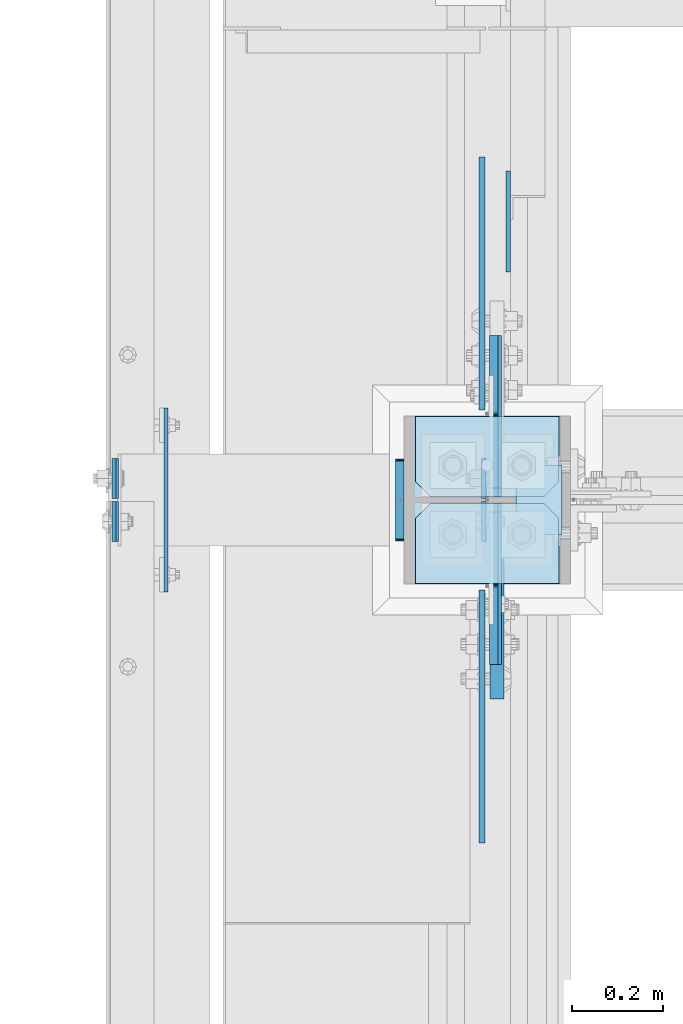
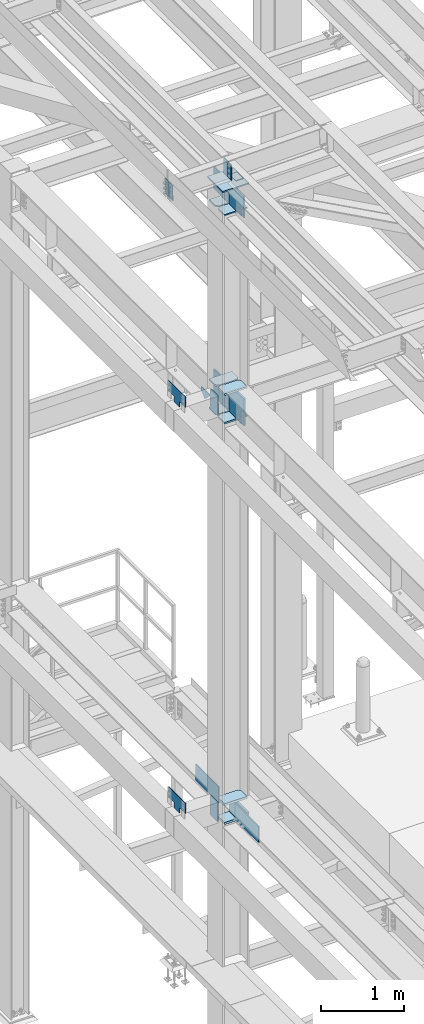
# One storey, part 3390 of 3843: 26 plates, 5 elements without a shape of their own.
"""IFC2X3 building model written with IfcOpenShell, lengths in millimetres."""

from ifc_helpers import new_model, si_unit, frame, origin_with_axes, place, context, subcontext, project, spatial, faceted_brep, material, type_object, element, aggregate, save


model = new_model("IFC2X3")

# Units and contexts
model_context = context("Model", 3, precision=1e-05, world=origin_with_axes())
body_context = subcontext(model_context, "Body", "Model", "MODEL_VIEW")
ifc_project = project(units=[si_unit("LENGTHUNIT", "METRE", prefix="MILLI"), si_unit("AREAUNIT", "SQUARE_METRE"), si_unit("VOLUMEUNIT", "CUBIC_METRE"), si_unit("MASSUNIT", "GRAM", prefix="KILO"), si_unit("TIMEUNIT", "SECOND"), si_unit("PLANEANGLEUNIT", "RADIAN"), si_unit("SOLIDANGLEUNIT", "STERADIAN"), si_unit("THERMODYNAMICTEMPERATUREUNIT", "DEGREE_CELSIUS"), si_unit("LUMINOUSINTENSITYUNIT", "LUMEN")], contexts=[model_context])

# Site, building, storey
site_placement = place(None, origin_with_axes())
site = spatial("IfcSite", under=ifc_project, at=site_placement, CompositionType="ELEMENT")
building_placement = place(site_placement, origin_with_axes())
building = spatial("IfcBuilding", under=site, at=building_placement, Name="Undefined", CompositionType="ELEMENT")
storey_placement = place(building_placement, origin_with_axes())
storey = spatial("IfcBuildingStorey", under=building, at=storey_placement, Name="Undefined", CompositionType="ELEMENT", Elevation=0.0)

# Assembly, plates
assembly_1_placement = place(storey_placement, origin_with_axes())
assembly_1 = element("IfcElementAssembly", 1, at=assembly_1_placement, inside=storey, Name="COLUMN", AssemblyPlace="NOTDEFINED", PredefinedType="RIGID_FRAME")
ifc_material = material(Name="STEEL/A572-50")
plate_type_1 = type_object("IfcPlateType", PredefinedType="NOTDEFINED")
plate_1_placement = place(assembly_1_placement, frame((36417.25, 83800.15625, 42005.249987793), z_axis=(1.0, 0.0, 0.0), x_axis=(0.0, 1.0, 0.0)))
plate_1 = element("IfcPlate", 2, at=plate_1_placement, type_object=plate_type_1, material=ifc_material, Name="PLATE", context=body_context, shape_type="Brep", body=[
    faceted_brep([(0.0, -12.6999999999971, 0.0), (0.0, -12.7000000020344, 317.500000001608), (0.0, 12.6999999977998, 317.500000001586), (0.0, 12.6999999999971, 0.0), (144.462501525879, -12.6999999999971, 317.5), (144.462501525879, 12.6999999999971, 317.5), (177.800003051758, -12.6999999999971, 284.162498474121), (177.800003051758, 12.6999999999971, 284.162498474121), (177.800003051758, -12.6999999999971, 33.3375015258789), (177.800003051758, 12.6999999999971, 33.3375015258789), (144.462501525879, -12.6999999999971, 0.0), (144.462501525879, 12.6999999999971, 0.0)], [[[0, 1, 2, 3]], [[1, 4, 5, 2]], [[4, 6, 7, 5]], [[6, 8, 9, 7]], [[8, 10, 11, 9]], [[10, 0, 3, 11]], [[5, 7, 9, 11, 3, 2]], [[10, 8, 6, 4, 1, 0]]]),
])
plate_2_placement = place(assembly_1_placement, frame((36417.25, 83800.15625, 42424.35), z_axis=(1.0, 0.0, 0.0), x_axis=(0.0, 1.0, 0.0)))
plate_2 = element("IfcPlate", 3, at=plate_2_placement, type_object=plate_type_1, material=ifc_material, Name="PLATE", context=body_context, shape_type="Brep", body=[
    faceted_brep([(0.0, -12.6999999999971, 0.0), (0.0, -12.7000000020344, 317.500000001608), (0.0, 12.6999999977998, 317.500000001586), (0.0, 12.6999999999971, 0.0), (144.462501525879, -12.6999999999971, 317.5), (144.462501525879, 12.6999999999971, 317.5), (177.800003051758, -12.6999999999971, 284.162498474121), (177.800003051758, 12.6999999999971, 284.162498474121), (177.800003051758, -12.6999999999971, 33.3375015258789), (177.800003051758, 12.6999999999971, 33.3375015258789), (144.462501525879, -12.6999999999971, 0.0), (144.462501525879, 12.6999999999971, 0.0)], [[[0, 1, 2, 3]], [[1, 4, 5, 2]], [[4, 6, 7, 5]], [[6, 8, 9, 7]], [[8, 10, 11, 9]], [[10, 0, 3, 11]], [[5, 7, 9, 11, 3, 2]], [[10, 8, 6, 4, 1, 0]]]),
])
plate_3_placement = place(assembly_1_placement, frame((36734.75, 84170.04375, 42005.249987793), z_axis=(-1.0, 0.0, 0.0), x_axis=(0.0, -1.0, 0.0)))
plate_3 = element("IfcPlate", 4, at=plate_3_placement, type_object=plate_type_1, material=ifc_material, Name="PLATE", context=body_context, shape_type="Brep", body=[
    faceted_brep([(0.0, -12.6999999999971, 0.0), (0.0, -12.7000000020344, 317.500000001608), (0.0, 12.6999999977998, 317.500000001586), (0.0, 12.6999999999971, 0.0), (144.462501525879, -12.6999999999971, 317.5), (144.462501525879, 12.6999999999971, 317.5), (177.800003051758, -12.6999999999971, 284.162498474121), (177.800003051758, 12.6999999999971, 284.162498474121), (177.800003051758, -12.6999999999971, 33.3375015258789), (177.800003051758, 12.6999999999971, 33.3375015258789), (144.462501525879, -12.6999999999971, 0.0), (144.462501525879, 12.6999999999971, 0.0)], [[[0, 1, 2, 3]], [[1, 4, 5, 2]], [[4, 6, 7, 5]], [[6, 8, 9, 7]], [[8, 10, 11, 9]], [[10, 0, 3, 11]], [[5, 7, 9, 11, 3, 2]], [[10, 8, 6, 4, 1, 0]]]),
])
plate_4_placement = place(assembly_1_placement, frame((36734.75, 84170.04375, 42424.35), z_axis=(-1.0, 0.0, 0.0), x_axis=(0.0, -1.0, 0.0)))
plate_4 = element("IfcPlate", 5, at=plate_4_placement, type_object=plate_type_1, material=ifc_material, Name="PLATE", context=body_context, shape_type="Brep", body=[
    faceted_brep([(0.0, -12.6999999999971, 0.0), (0.0, -12.7000000020344, 317.500000001608), (0.0, 12.6999999977998, 317.500000001586), (0.0, 12.6999999999971, 0.0), (144.462501525879, -12.6999999999971, 317.5), (144.462501525879, 12.6999999999971, 317.5), (177.800003051758, -12.6999999999971, 284.162498474121), (177.800003051758, 12.6999999999971, 284.162498474121), (177.800003051758, -12.6999999999971, 33.3375015258789), (177.800003051758, 12.6999999999971, 33.3375015258789), (144.462501525879, -12.6999999999971, 0.0), (144.462501525879, 12.6999999999971, 0.0)], [[[0, 1, 2, 3]], [[1, 4, 5, 2]], [[4, 6, 7, 5]], [[6, 8, 9, 7]], [[8, 10, 11, 9]], [[10, 0, 3, 11]], [[5, 7, 9, 11, 3, 2]], [[10, 8, 6, 4, 1, 0]]]),
])
plate_type_2 = type_object("IfcPlateType", PredefinedType="NOTDEFINED")
plate_5_placement = place(assembly_1_placement, frame((36595.0499999046, 83977.95625, 42411.65), z_axis=(0.0, -1.0, 0.0), x_axis=(0.0, 0.0, -1.0)))
plate_5 = element("IfcPlate", 6, at=plate_5_placement, type_object=plate_type_2, material=ifc_material, Name="PLATE", context=body_context, shape_type="Brep", body=[
    faceted_brep([(0.0, -12.6999999999971, 19.0499992370605), (0.0, -12.6999999999971, 356.393737792969), (0.0, 12.6999999999971, 356.393737792969), (0.0, 12.6999999999971, 19.0499992370605), (393.700012207031, -12.6999999999971, 356.393737792969), (393.700012207031, 12.6999999999971, 356.393737792969), (393.700012207031, -12.6999999999971, 19.0499992370605), (393.700012207031, 12.6999999999971, 19.0499992370605), (374.650012969971, -12.6999999999971, 0.0), (374.650012969971, 12.6999999999971, 0.0), (19.0500015258731, -12.6999999999971, -6.33008312433958e-10), (19.0500015258731, 12.6999999999971, 0.0)], [[[0, 1, 2, 3]], [[1, 4, 5, 2]], [[4, 6, 7, 5]], [[6, 8, 9, 7]], [[8, 10, 11, 9]], [[10, 0, 3, 11]], [[5, 7, 9, 11, 3, 2]], [[10, 8, 6, 4, 1, 0]]]),
])
plate_6_placement = place(assembly_1_placement, frame((36595.0499999046, 83992.24375, 42411.65), z_axis=(0.0, 1.0, 0.0), x_axis=(0.0, 0.0, -1.0)))
plate_6 = element("IfcPlate", 7, at=plate_6_placement, type_object=plate_type_2, material=ifc_material, Name="PLATE", context=body_context, shape_type="Brep", body=[
    faceted_brep([(0.0, -12.6999999999971, 19.0499992370605), (0.0, -12.6999999999971, 356.393737792969), (0.0, 12.6999999999971, 356.393737792969), (0.0, 12.6999999999971, 19.0499992370605), (393.700012207031, -12.6999999999971, 356.393737792969), (393.700012207031, 12.6999999999971, 356.393737792969), (393.700012207031, -12.6999999999971, 19.0499992370605), (393.700012207031, 12.6999999999971, 19.0499992370605), (374.650012969971, -12.6999999999971, 0.0), (374.650012969971, 12.6999999999971, 0.0), (19.0500015258731, -12.6999999999971, -6.33008312433958e-10), (19.0500015258731, 12.6999999999971, 0.0)], [[[0, 1, 2, 3]], [[1, 4, 5, 2]], [[4, 6, 7, 5]], [[6, 8, 9, 7]], [[8, 10, 11, 9]], [[10, 0, 3, 11]], [[5, 7, 9, 11, 3, 2]], [[10, 8, 6, 4, 1, 0]]]),
])

assembly_2_placement = place(storey_placement, origin_with_axes())
assembly_2 = element("IfcElementAssembly", 8, at=assembly_2_placement, inside=storey, Name="BEAM", AssemblyPlace="NOTDEFINED", PredefinedType="RIGID_FRAME")
plate_type_3 = type_object("IfcPlateType", PredefinedType="NOTDEFINED")
plate_7_placement = place(assembly_2_placement, frame((36568.0624999913, 83981.925, 45691.494629371), z_axis=(0.0, -1.0, 0.0), x_axis=(0.0, 0.0, -1.0)))
plate_7 = element("IfcPlate", 9, at=plate_7_placement, type_object=plate_type_3, material=ifc_material, Name="PLATE", context=body_context, shape_type="Brep", body=[
    faceted_brep([(0.0, -4.76249999999709, 0.0), (0.0, -4.76249999999709, 88.9000015258789), (0.0, 4.76249999999709, 88.9000015258789), (0.0, 4.76249999999709, 0.0), (228.600006102781, -4.7625000004191, 88.9000015257589), (228.600006102781, 4.76249999954598, 88.9000015257443), (228.600006103079, -4.7625000004482, 7.27595761418343e-12), (228.600006103079, 4.76249999954598, -7.27595761418343e-12)], [[[0, 1, 2, 3]], [[1, 4, 5, 2]], [[4, 6, 7, 5]], [[6, 0, 3, 7]], [[5, 7, 3, 2]], [[6, 4, 1, 0]]]),
])
plate_8_placement = place(assembly_2_placement, frame((36568.062499997, 83988.275, 45691.4946293711), z_axis=(0.0, 1.0, 0.0), x_axis=(0.0, 0.0, -1.0)))
plate_8 = element("IfcPlate", 10, at=plate_8_placement, type_object=plate_type_3, material=ifc_material, Name="PLATE", context=body_context, shape_type="Brep", body=[
    faceted_brep([(0.0, -4.76249999999709, 0.0), (0.0, -4.76249999999709, 88.9000015258789), (0.0, 4.76249999999709, 88.9000015258789), (0.0, 4.76249999999709, 0.0), (228.600006102781, -4.7625000004191, 88.9000015257589), (228.600006102781, 4.76249999954598, 88.9000015257443), (228.600006103079, -4.7625000004482, 7.27595761418343e-12), (228.600006103079, 4.76249999954598, -7.27595761418343e-12)], [[[0, 1, 2, 3]], [[1, 4, 5, 2]], [[4, 6, 7, 5]], [[6, 0, 3, 7]], [[5, 7, 3, 2]], [[6, 4, 1, 0]]]),
])
plate_9_placement = place(assembly_2_placement, frame((35751.3030535553, 83981.925, 45674.0381290301), z_axis=(0.0, -1.0, 0.0), x_axis=(0.0211520550054438, 0.0, -0.999776270257025)))
plate_9 = element("IfcPlate", 11, at=plate_9_placement, type_object=plate_type_3, material=ifc_material, Name="PLATE", context=body_context, shape_type="Brep", body=[
    faceted_brep([(0.0, -4.76249999999709, 0.0), (0.0, -4.76249999999709, 88.9000015258789), (0.0, 4.76249999999709, 88.9000015258789), (0.0, 4.76249999999709, 0.0), (228.600006102781, -4.7625000004191, 88.9000015257589), (228.600006102781, 4.76249999954598, 88.9000015257443), (228.600006103079, -4.7625000004482, 7.27595761418343e-12), (228.600006103079, 4.76249999954598, -7.27595761418343e-12)], [[[0, 1, 2, 3]], [[1, 4, 5, 2]], [[4, 6, 7, 5]], [[6, 0, 3, 7]], [[5, 7, 3, 2]], [[6, 4, 1, 0]]]),
])
plate_10_placement = place(assembly_2_placement, frame((35751.303053558, 83988.275, 45674.0381290373), z_axis=(0.0, 1.0, 0.0), x_axis=(0.0211520550054438, 0.0, -0.999776270257025)))
plate_10 = element("IfcPlate", 12, at=plate_10_placement, type_object=plate_type_3, material=ifc_material, Name="PLATE", context=body_context, shape_type="Brep", body=[
    faceted_brep([(0.0, -4.76249999999709, 0.0), (0.0, -4.76249999999709, 88.9000015258789), (0.0, 4.76249999999709, 88.9000015258789), (0.0, 4.76249999999709, 0.0), (228.600006102781, -4.7625000004191, 88.9000015257589), (228.600006102781, 4.76249999954598, 88.9000015257443), (228.600006103079, -4.7625000004482, 7.27595761418343e-12), (228.600006103079, 4.76249999954598, -7.27595761418343e-12)], [[[0, 1, 2, 3]], [[1, 4, 5, 2]], [[4, 6, 7, 5]], [[6, 0, 3, 7]], [[5, 7, 3, 2]], [[6, 4, 1, 0]]]),
])
aggregate(assembly_2, [plate_7, plate_8, plate_9, plate_10])

# Plate
plate_type_4 = type_object("IfcPlateType", PredefinedType="NOTDEFINED")
plate_11_placement = place(assembly_1_placement, frame((36639.5, 84061.3000000002, 45422.542188), z_axis=(1.0, 0.0, 0.0), x_axis=(0.0, -1.0, 0.0)))
plate_11 = element("IfcPlate", 13, at=plate_11_placement, type_object=plate_type_4, material=ifc_material, Name="PLATE", context=body_context, shape_type="Brep", body=[
    faceted_brep([(0.0, -3.17499999999927, 0.0), (0.0, -3.17499999999927, 101.600000000006), (0.0, 3.17499999999927, 101.600000000006), (0.0, 3.17499999999927, 0.0), (152.399998474109, -3.17500000000291, 101.599998474121), (152.399998474109, 3.17500000000291, 101.599998474121), (152.399998474109, -3.17500000000291, 0.0), (152.399998474109, 3.17500000000291, 0.0)], [[[0, 1, 2, 3]], [[1, 4, 5, 2]], [[4, 6, 7, 5]], [[6, 0, 3, 7]], [[5, 7, 3, 2]], [[6, 4, 1, 0]]]),
])

plate_type_5 = type_object("IfcPlateType", PredefinedType="NOTDEFINED")
plate_12_placement = place(assembly_1_placement, frame((36734.75, 84170.04375, 45059.5999999999), z_axis=(-1.0, 0.0, 0.0), x_axis=(0.0, -1.0, 0.0)))
plate_12 = element("IfcPlate", 14, at=plate_12_placement, type_object=plate_type_5, material=ifc_material, Name="PLATE", context=body_context, shape_type="Brep", body=[
    faceted_brep([(0.0, -9.52500000000146, 0.0), (0.0, -9.52500000000146, 317.5), (0.0, 9.52500000000146, 317.5), (0.0, 9.52500000000146, 0.0), (144.462501525879, -9.52500000000146, 317.5), (144.462501525879, 9.52500000000146, 317.5), (177.800003051758, -9.52500000000146, 284.162498474121), (177.800003051758, 9.52500000000146, 284.162498474121), (177.800003051758, -9.52500000000146, 33.3375015258789), (177.800003051758, 9.52500000000146, 33.3375015258789), (144.462501525879, -9.52500000000146, 0.0), (144.462501525879, 9.52500000000146, 0.0)], [[[0, 1, 2, 3]], [[1, 4, 5, 2]], [[4, 6, 7, 5]], [[6, 8, 9, 7]], [[8, 10, 11, 9]], [[10, 0, 3, 11]], [[5, 7, 9, 11, 3, 2]], [[10, 8, 6, 4, 1, 0]]]),
])

plate_13_placement = place(assembly_1_placement, frame((36417.25, 83800.15625, 45059.5999999884), z_axis=(1.0, 0.0, 0.0), x_axis=(0.0, 1.0, 0.0)))
plate_13 = element("IfcPlate", 15, at=plate_13_placement, type_object=plate_type_5, material=ifc_material, Name="PLATE", context=body_context, shape_type="Brep", body=[
    faceted_brep([(0.0, -9.52500000000146, 0.0), (0.0, -9.52500000000146, 317.5), (0.0, 9.52500000000146, 317.5), (0.0, 9.52500000000146, 0.0), (144.462501525879, -9.52500000000146, 317.5), (144.462501525879, 9.52500000000146, 317.5), (177.800003051758, -9.52500000000146, 284.162498474121), (177.800003051758, 9.52500000000146, 284.162498474121), (177.800003051758, -9.52500000000146, 33.3375015258789), (177.800003051758, 9.52500000000146, 33.3375015258789), (144.462501525879, -9.52500000000146, 0.0), (144.462501525879, 9.52500000000146, 0.0)], [[[0, 1, 2, 3]], [[1, 4, 5, 2]], [[4, 6, 7, 5]], [[6, 8, 9, 7]], [[8, 10, 11, 9]], [[10, 0, 3, 11]], [[5, 7, 9, 11, 3, 2]], [[10, 8, 6, 4, 1, 0]]]),
])

plate_type_6 = type_object("IfcPlateType", PredefinedType="NOTDEFINED")
plate_14_placement = place(assembly_1_placement, frame((35866.3875, 84048.6, 36404.55), z_axis=(0.0, 0.0, 1.0), x_axis=(0.0, -1.0, 0.0)))
plate_14 = element("IfcPlate", 16, at=plate_14_placement, type_object=plate_type_6, material=ifc_material, Name="PLATE", context=body_context, shape_type="Brep", body=[
    faceted_brep([(0.0, -4.76249999999709, 0.0), (-3.49245965480804e-10, -4.76249999999709, 76.1999999999462), (-3.49245965480804e-10, 4.76249999999709, 76.1999999999462), (0.0, 4.76249999999709, 0.0), (-139.699996948242, -4.76249999999709, 76.1999969482422), (-139.699996948242, 4.76249999999709, 76.1999969482422), (-139.699996948242, -4.76249999999709, 228.600006103516), (-139.699996948242, 4.76249999999709, 228.600006103516), (266.700012207031, -4.76249999999709, 228.600006103516), (266.700012207031, 4.76249999999709, 228.600006103516), (266.700012207031, -4.76249999999709, 76.1999969482422), (266.700012207031, 4.76249999999709, 76.1999969482422), (126.999992370605, -4.76249999999709, 76.1999969482422), (126.999992370605, 4.76249999999709, 76.1999969482422), (126.999992370605, -4.76249999999709, 0.0), (126.999992370605, 4.76249999999709, 0.0)], [[[0, 1, 2, 3]], [[1, 4, 5, 2]], [[4, 6, 7, 5]], [[6, 8, 9, 7]], [[8, 10, 11, 9]], [[10, 12, 13, 11]], [[12, 14, 15, 13]], [[14, 0, 3, 15]], [[5, 7, 9, 11, 13, 15, 3, 2]], [[14, 12, 10, 8, 6, 4, 1, 0]]]),
])

plate_15_placement = place(assembly_1_placement, frame((35866.3875, 84048.6, 42367.2), z_axis=(0.0, 0.0, 1.0), x_axis=(0.0, -1.0, 0.0)))
plate_15 = element("IfcPlate", 17, at=plate_15_placement, type_object=plate_type_6, material=ifc_material, Name="PLATE", context=body_context, shape_type="Brep", body=[
    faceted_brep([(0.0, -4.76249999999709, 0.0), (-3.49245965480804e-10, -4.76249999999709, 76.1999999999462), (-3.49245965480804e-10, 4.76249999999709, 76.1999999999462), (0.0, 4.76249999999709, 0.0), (-139.699996948242, -4.76249999999709, 76.1999969482422), (-139.699996948242, 4.76249999999709, 76.1999969482422), (-139.699996948242, -4.76249999999709, 228.600006103516), (-139.699996948242, 4.76249999999709, 228.600006103516), (266.700012207031, -4.76249999999709, 228.600006103516), (266.700012207031, 4.76249999999709, 228.600006103516), (266.700012207031, -4.76249999999709, 76.1999969482422), (266.700012207031, 4.76249999999709, 76.1999969482422), (126.999992370605, -4.76249999999709, 76.1999969482422), (126.999992370605, 4.76249999999709, 76.1999969482422), (126.999992370605, -4.76249999999709, 0.0), (126.999992370605, 4.76249999999709, 0.0)], [[[0, 1, 2, 3]], [[1, 4, 5, 2]], [[4, 6, 7, 5]], [[6, 8, 9, 7]], [[8, 10, 11, 9]], [[10, 12, 13, 11]], [[12, 14, 15, 13]], [[14, 0, 3, 15]], [[5, 7, 9, 11, 13, 15, 3, 2]], [[14, 12, 10, 8, 6, 4, 1, 0]]]),
])

plate_type_7 = type_object("IfcPlateType", PredefinedType="NOTDEFINED")
plate_16_placement = place(assembly_1_placement, frame((36382.325, 83894.6125, 42356.4551879883), z_axis=(0.0, 1.0, 0.0), x_axis=(0.0, 0.0, -1.0)))
plate_16 = element("IfcPlate", 18, at=plate_16_placement, type_object=plate_type_7, material=ifc_material, Name="PLATE", context=body_context, shape_type="Brep", body=[
    faceted_brep([(-8.22591685395256e-13, -9.52499999999854, 7.9375), (0.0, -9.52499999999418, 173.037499999991), (0.0, 9.52499999999418, 173.037499999991), (0.0, 9.52499999999418, 7.9375), (0.604206210693519, -9.52499999999418, 176.075049744395), (0.604206210693519, 9.52499999999418, 176.075049744395), (2.32483992433117, -9.52499999999418, 178.65016007566), (2.32483992433117, 9.52499999999418, 178.65016007566), (4.89995025560347, -9.52499999999418, 180.370793789305), (4.89995025560347, 9.52499999999418, 180.370793789305), (7.9375, -9.52499999999418, 180.974999999991), (7.9375, 9.52499999999418, 180.974999999991), (274.637499999997, -9.52499999999418, 180.974999999991), (274.637499999997, 9.52499999999418, 180.974999999991), (277.675049744394, -9.52499999999418, 180.370793789305), (277.675049744394, 9.52499999999418, 180.370793789305), (280.250160075666, -9.52499999999418, 178.65016007566), (280.250160075666, 9.52499999999418, 178.65016007566), (281.970793789304, -9.52499999999418, 176.075049744395), (281.970793789304, 9.52499999999418, 176.075049744395), (282.574999999997, -9.52499999999418, 173.037499999991), (282.574999999997, 9.52499999999418, 173.037499999991), (282.574999999997, -9.52499999999418, 7.9375), (282.574999999997, 9.52499999999418, 7.9375), (281.970793789304, -9.52499999999418, 4.8999502555962), (281.970793789304, 9.52499999999418, 4.8999502555962), (280.250160075666, -9.52499999999418, 2.32483992433117), (280.250160075666, 9.52499999999418, 2.32483992433117), (277.675049744394, -9.52499999999418, 0.604206210686243), (277.675049744394, 9.52499999999418, 0.604206210686243), (274.637499999997, -9.52499999999418, 0.0), (274.637499999997, 9.52499999999418, 0.0), (7.9375, -9.52499999999854, 0.0), (7.9375, 9.52499999999418, 0.0), (4.8999502555962, -9.52499999999418, 0.604206210693519), (4.8999502555962, 9.52499999999418, 0.604206210693519), (2.32483992433117, -9.52499999999418, 2.32483992433117), (2.32483992433117, 9.52499999999418, 2.32483992433117), (0.604206210686243, -9.52499999999418, 4.89995025560347), (0.604206210686243, 9.52499999999418, 4.89995025560347)], [[[0, 1, 2, 3]], [[1, 4, 5, 2]], [[4, 6, 7, 5]], [[6, 8, 9, 7]], [[8, 10, 11, 9]], [[10, 12, 13, 11]], [[12, 14, 15, 13]], [[14, 16, 17, 15]], [[16, 18, 19, 17]], [[18, 20, 21, 19]], [[20, 22, 23, 21]], [[22, 24, 25, 23]], [[24, 26, 27, 25]], [[26, 28, 29, 27]], [[28, 30, 31, 29]], [[30, 32, 33, 31]], [[32, 34, 35, 33]], [[34, 36, 37, 35]], [[36, 38, 39, 37]], [[38, 0, 3, 39]], [[5, 7, 9, 11, 13, 15, 17, 19, 21, 23, 25, 27, 29, 31, 33, 35, 37, 39, 3, 2]], [[38, 36, 34, 32, 30, 28, 26, 24, 22, 20, 18, 16, 14, 12, 10, 8, 6, 4, 1, 0]]]),
])

plate_17_placement = place(assembly_1_placement, frame((36382.325, 83894.6125, 36393.4375), z_axis=(0.0, 1.0, 0.0), x_axis=(0.0, 0.0, -1.0)))
plate_17 = element("IfcPlate", 19, at=plate_17_placement, type_object=plate_type_7, material=ifc_material, Name="PLATE", context=body_context, shape_type="Brep", body=[
    faceted_brep([(-8.22591685395256e-13, -9.52499999999854, 7.9375), (0.0, -9.52499999999418, 173.037499999991), (0.0, 9.52499999999418, 173.037499999991), (0.0, 9.52499999999418, 7.9375), (0.604206210693519, -9.52499999999418, 176.075049744395), (0.604206210693519, 9.52499999999418, 176.075049744395), (2.32483992433117, -9.52499999999418, 178.65016007566), (2.32483992433117, 9.52499999999418, 178.65016007566), (4.89995025560347, -9.52499999999418, 180.370793789305), (4.89995025560347, 9.52499999999418, 180.370793789305), (7.9375, -9.52499999999418, 180.974999999991), (7.9375, 9.52499999999418, 180.974999999991), (274.637499999997, -9.52499999999418, 180.974999999991), (274.637499999997, 9.52499999999418, 180.974999999991), (277.675049744394, -9.52499999999418, 180.370793789305), (277.675049744394, 9.52499999999418, 180.370793789305), (280.250160075666, -9.52499999999418, 178.65016007566), (280.250160075666, 9.52499999999418, 178.65016007566), (281.970793789304, -9.52499999999418, 176.075049744395), (281.970793789304, 9.52499999999418, 176.075049744395), (282.574999999997, -9.52499999999418, 173.037499999991), (282.574999999997, 9.52499999999418, 173.037499999991), (282.574999999997, -9.52499999999418, 7.9375), (282.574999999997, 9.52499999999418, 7.9375), (281.970793789304, -9.52499999999418, 4.8999502555962), (281.970793789304, 9.52499999999418, 4.8999502555962), (280.250160075666, -9.52499999999418, 2.32483992433117), (280.250160075666, 9.52499999999418, 2.32483992433117), (277.675049744394, -9.52499999999418, 0.604206210686243), (277.675049744394, 9.52499999999418, 0.604206210686243), (274.637499999997, -9.52499999999418, 0.0), (274.637499999997, 9.52499999999418, 0.0), (7.9375, -9.52499999999854, 0.0), (7.9375, 9.52499999999418, 0.0), (4.8999502555962, -9.52499999999418, 0.604206210693519), (4.8999502555962, 9.52499999999418, 0.604206210693519), (2.32483992433117, -9.52499999999418, 2.32483992433117), (2.32483992433117, 9.52499999999418, 2.32483992433117), (0.604206210686243, -9.52499999999418, 4.89995025560347), (0.604206210686243, 9.52499999999418, 4.89995025560347)], [[[0, 1, 2, 3]], [[1, 4, 5, 2]], [[4, 6, 7, 5]], [[6, 8, 9, 7]], [[8, 10, 11, 9]], [[10, 12, 13, 11]], [[12, 14, 15, 13]], [[14, 16, 17, 15]], [[16, 18, 19, 17]], [[18, 20, 21, 19]], [[20, 22, 23, 21]], [[22, 24, 25, 23]], [[24, 26, 27, 25]], [[26, 28, 29, 27]], [[28, 30, 31, 29]], [[30, 32, 33, 31]], [[32, 34, 35, 33]], [[34, 36, 37, 35]], [[36, 38, 39, 37]], [[38, 0, 3, 39]], [[5, 7, 9, 11, 13, 15, 17, 19, 21, 23, 25, 27, 29, 31, 33, 35, 37, 39, 3, 2]], [[38, 36, 34, 32, 30, 28, 26, 24, 22, 20, 18, 16, 14, 12, 10, 8, 6, 4, 1, 0]]]),
])

plate_type_8 = type_object("IfcPlateType", PredefinedType="NOTDEFINED")
plate_18_placement = place(assembly_1_placement, frame((36417.25, 83800.15625, 36128.325), z_axis=(1.0, 0.0, 0.0), x_axis=(0.0, 1.0, 0.0)))
plate_18 = element("IfcPlate", 20, at=plate_18_placement, type_object=plate_type_8, material=ifc_material, Name="PLATE", context=body_context, shape_type="Brep", body=[
    faceted_brep([(0.0, -15.875, 0.0), (0.0, -15.875, 317.5), (0.0, 15.875, 317.5), (0.0, 15.875, 0.0), (144.462498511086, -15.874999999156, 317.499999999665), (144.462498511086, 15.875000000844, 317.499999999578), (177.800000033079, -15.8749999992506, 284.162498473786), (177.800000033079, 15.8750000007494, 284.162498473699), (177.800000003888, -15.8749999999054, 33.3375015259226), (177.800000003888, 15.8750000000946, 33.3375015258353), (144.462498474124, -15.875, 0.0), (144.462498474124, 15.875, 0.0)], [[[0, 1, 2, 3]], [[1, 4, 5, 2]], [[4, 6, 7, 5]], [[6, 8, 9, 7]], [[8, 10, 11, 9]], [[10, 0, 3, 11]], [[5, 7, 9, 11, 3, 2]], [[10, 8, 6, 4, 1, 0]]]),
])

plate_19_placement = place(assembly_1_placement, frame((36417.25, 83800.15625, 36401.375), z_axis=(1.0, 0.0, 0.0), x_axis=(0.0, 1.0, 0.0)))
plate_19 = element("IfcPlate", 21, at=plate_19_placement, type_object=plate_type_8, material=ifc_material, Name="PLATE", context=body_context, shape_type="Brep", body=[
    faceted_brep([(0.0, -15.875, 0.0), (0.0, -15.875, 317.5), (0.0, 15.875, 317.5), (0.0, 15.875, 0.0), (144.462498511086, -15.874999999156, 317.499999999665), (144.462498511086, 15.875000000844, 317.499999999578), (177.800000033079, -15.8749999992506, 284.162498473786), (177.800000033079, 15.8750000007494, 284.162498473699), (177.800000003888, -15.8749999999054, 33.3375015259226), (177.800000003888, 15.8750000000946, 33.3375015258353), (144.462498474124, -15.875, 0.0), (144.462498474124, 15.875, 0.0)], [[[0, 1, 2, 3]], [[1, 4, 5, 2]], [[4, 6, 7, 5]], [[6, 8, 9, 7]], [[8, 10, 11, 9]], [[10, 0, 3, 11]], [[5, 7, 9, 11, 3, 2]], [[10, 8, 6, 4, 1, 0]]]),
])

# Assembly, plate
assembly_3_placement = place(storey_placement, origin_with_axes())
assembly_3 = element("IfcElementAssembly", 22, at=assembly_3_placement, inside=storey, Name="BEAM", AssemblyPlace="NOTDEFINED", PredefinedType="RIGID_FRAME")
plate_type_9 = type_object("IfcPlateType", PredefinedType="NOTDEFINED")
plate_20_placement = place(assembly_3_placement, frame((36622.0375, 84488.9289773786, 41925.875), z_axis=(0.0, 0.707106781186548, 0.707106781186548), x_axis=(5.70000238222118e-08, 0.707106781186546, -0.707106781186546)))
plate_20 = element("IfcPlate", 23, at=plate_20_placement, type_object=plate_type_9, material=ifc_material, Name="PLATE", context=body_context, shape_type="Brep", body=[
    faceted_brep([(0.0, -4.76249999999709, 0.0), (157.726597423803, -4.76249999999709, 157.726601438866), (157.726597423803, 4.76249999999709, 157.726601438866), (0.0, 4.76249999999709, 0.0), (188.387110059113, -4.76249999999709, 127.066089584019), (188.387110059113, 4.76249999999709, 127.066089584019), (188.387111679331, -4.76249999999709, 1.09139364212751e-10), (188.387111679331, 4.76249999999709, 1.09139364212751e-10)], [[[0, 1, 2, 3]], [[1, 4, 5, 2]], [[4, 6, 7, 5]], [[6, 0, 3, 7]], [[5, 7, 3, 2]], [[6, 4, 1, 0]]]),
])
aggregate(assembly_3, [plate_20])

# Plate
plate_type_10 = type_object("IfcPlateType", PredefinedType="NOTDEFINED")
plate_21_placement = place(assembly_1_placement, frame((36760.15, 83799.3625, 45408.1254169701), z_axis=(-1.0, 0.0, 0.0), x_axis=(0.0, 1.0, 0.0)))
plate_21 = element("IfcPlate", 24, at=plate_21_placement, type_object=plate_type_10, material=ifc_material, Name="PLATE", context=body_context, shape_type="Brep", body=[
    faceted_brep([(0.0, -9.52500000000146, 0.0), (0.0, -9.52500000015425, 368.299999993164), (0.0, 9.52499999984866, 368.299999993018), (0.0, 9.52500000000146, 0.0), (371.474999999991, -9.52500000015425, 368.299999993149), (371.474999999991, 9.52499999984866, 368.299999993003), (371.474999999991, -9.52500000000146, 4.36557456851006e-11), (371.474999999991, 9.52500000000873, -7.27595761418343e-11)], [[[0, 1, 2, 3]], [[1, 4, 5, 2]], [[4, 6, 7, 5]], [[6, 0, 3, 7]], [[5, 7, 3, 2]], [[6, 4, 1, 0]]]),
])

plate_type_11 = type_object("IfcPlateType", PredefinedType="NOTDEFINED")
plate_22_placement = place(assembly_1_placement, frame((36590.2875004626, 83992.24375, 45088.1750026622), z_axis=(0.0, 0.707106781186548, 0.707106781186548), x_axis=(5.70000238222118e-08, 0.707106781186546, -0.707106781186546)))
plate_22 = element("IfcPlate", 25, at=plate_22_placement, type_object=plate_type_11, material=ifc_material, Name="PLATE", context=body_context, shape_type="Brep", body=[
    faceted_brep([(0.0, -9.52500000000146, 0.0), (-205.423360299239, -9.52500000000146, 205.423357237712), (-205.423360299239, 9.52500000000146, 205.423357237712), (0.0, 9.52500000000146, 0.0), (-205.423360299126, -9.52500000000146, 232.3641254002), (-205.423360299126, 9.52500000000146, 232.3641254002), (-92.608892539698, -9.52500000000146, 345.178591747157), (-92.608892539698, 9.52500000000146, 345.178591747157), (-89.0037379960995, -9.52500000000146, 342.769704533581), (-89.0037379960995, 9.52500000000146, 342.769704533581), (-84.751168274659, -9.52500000000146, 341.923815855786), (-84.751168274659, 9.52500000000146, 341.923815855786), (-80.4985985658241, -9.52500000000146, 342.769704596954), (-80.4985985658241, 9.52500000000146, 342.769704596954), (-76.8934440581252, -9.52500000000146, 345.178591864264), (-76.8934440581252, 9.52500000000146, 345.178591864264), (40.9724185538689, -9.52500000000146, 463.044456243078), (40.9724185538689, 9.52500000000146, 463.044456243078), (265.478821579974, -9.52500000000146, 238.538053217882), (265.478821579974, 9.52500000000146, 238.538053217882), (26.9407683632344, -9.52499999999964, 2.03726813197136e-10), (26.9407683632344, 9.52499999999964, 2.03726813197136e-10)], [[[0, 1, 2, 3]], [[1, 4, 5, 2]], [[4, 6, 7, 5]], [[6, 8, 9, 7]], [[8, 10, 11, 9]], [[10, 12, 13, 11]], [[12, 14, 15, 13]], [[14, 16, 17, 15]], [[16, 18, 19, 17]], [[18, 20, 21, 19]], [[20, 0, 3, 21]], [[5, 7, 9, 11, 13, 15, 17, 19, 21, 3, 2]], [[20, 18, 16, 14, 12, 10, 8, 6, 4, 1, 0]]]),
])

plate_23_placement = place(assembly_1_placement, frame((36590.287500451, 83977.95625, 45088.1750026621), z_axis=(0.0, -0.707106781186682, 0.707106781186413), x_axis=(0.0, -0.707106781186548, -0.707106781186548)))
plate_23 = element("IfcPlate", 26, at=plate_23_placement, type_object=plate_type_11, material=ifc_material, Name="PLATE", context=body_context, shape_type="Brep", body=[
    faceted_brep([(0.0, -9.52500000000146, 0.0), (-205.423360299239, -9.52500000000146, 205.423357237712), (-205.423360299239, 9.52500000000146, 205.423357237712), (0.0, 9.52500000000146, 0.0), (-205.423360299126, -9.52500000000146, 232.3641254002), (-205.423360299126, 9.52500000000146, 232.3641254002), (-92.608892539698, -9.52500000000146, 345.178591747157), (-92.608892539698, 9.52500000000146, 345.178591747157), (-89.0037379960995, -9.52500000000146, 342.769704533581), (-89.0037379960995, 9.52500000000146, 342.769704533581), (-84.751168274659, -9.52500000000146, 341.923815855786), (-84.751168274659, 9.52500000000146, 341.923815855786), (-80.4985985658241, -9.52500000000146, 342.769704596954), (-80.4985985658241, 9.52500000000146, 342.769704596954), (-76.8934440581252, -9.52500000000146, 345.178591864264), (-76.8934440581252, 9.52500000000146, 345.178591864264), (40.9724185538689, -9.52500000000146, 463.044456243078), (40.9724185538689, 9.52500000000146, 463.044456243078), (265.478821579974, -9.52500000000146, 238.538053217882), (265.478821579974, 9.52500000000146, 238.538053217882), (26.9407683632344, -9.52499999999964, 2.03726813197136e-10), (26.9407683632344, 9.52499999999964, 2.03726813197136e-10)], [[[0, 1, 2, 3]], [[1, 4, 5, 2]], [[4, 6, 7, 5]], [[6, 8, 9, 7]], [[8, 10, 11, 9]], [[10, 12, 13, 11]], [[12, 14, 15, 13]], [[14, 16, 17, 15]], [[16, 18, 19, 17]], [[18, 20, 21, 19]], [[20, 0, 3, 21]], [[5, 7, 9, 11, 13, 15, 17, 19, 21, 3, 2]], [[20, 18, 16, 14, 12, 10, 8, 6, 4, 1, 0]]]),
])

# Assembly, plate
assembly_4_placement = place(storey_placement, origin_with_axes())
assembly_4 = element("IfcElementAssembly", 27, at=assembly_4_placement, inside=storey, Name="BEAM", AssemblyPlace="NOTDEFINED", PredefinedType="RIGID_FRAME")
plate_type_12 = type_object("IfcPlateType", PredefinedType="NOTDEFINED")
plate_24_placement = place(assembly_4_placement, frame((36564.09375, 83786.6625, 36385.5), z_axis=(0.0, -1.0, 0.0), x_axis=(0.0, 0.0, -1.0)))
plate_24 = element("IfcPlate", 28, at=plate_24_placement, type_object=plate_type_12, material=ifc_material, Name="PLATE", context=body_context, shape_type="Brep", body=[
    faceted_brep([(0.0, -6.3499999046162, 0.0), (-1.27693056128919e-09, -6.34999999999854, 558.800000006726), (0.0, 6.35000000000036, 558.799999999988), (7.27595761418343e-12, 6.3499999046162, 0.0), (241.300003051758, -6.34999999999854, 558.800012207037), (241.300003051758, 6.34999999999854, 558.800012207037), (241.300003051758, -6.34999999999854, 0.0), (241.300003051758, 6.34999999999854, 0.0)], [[[0, 1, 2, 3]], [[1, 4, 5, 2]], [[4, 6, 7, 5]], [[6, 0, 3, 7]], [[5, 7, 3, 2]], [[6, 4, 1, 0]]]),
])
aggregate(assembly_4, [plate_24])

assembly_5_placement = place(storey_placement, origin_with_axes())
assembly_5 = element("IfcElementAssembly", 29, at=assembly_5_placement, inside=storey, Name="BEAM", AssemblyPlace="NOTDEFINED", PredefinedType="RIGID_FRAME")
plate_25_placement = place(assembly_5_placement, frame((36564.09375, 84742.337512207, 36385.5), z_axis=(0.0, -1.0, 0.0), x_axis=(0.0, 0.0, -1.0)))
plate_25 = element("IfcPlate", 30, at=plate_25_placement, type_object=plate_type_12, material=ifc_material, Name="PLATE", context=body_context, shape_type="Brep", body=[
    faceted_brep([(0.0, -6.3499999046162, 0.0), (-1.27693056128919e-09, -6.34999999999854, 558.800000006726), (0.0, 6.35000000000036, 558.799999999988), (7.27595761418343e-12, 6.3499999046162, 0.0), (241.300003051758, -6.34999999999854, 558.800012207037), (241.300003051758, 6.34999999999854, 558.800012207037), (241.300003051758, -6.34999999999854, 0.0), (241.300003051758, 6.34999999999854, 0.0)], [[[0, 1, 2, 3]], [[1, 4, 5, 2]], [[4, 6, 7, 5]], [[6, 0, 3, 7]], [[5, 7, 3, 2]], [[6, 4, 1, 0]]]),
])
aggregate(assembly_5, [plate_25])

# Plate
plate_type_13 = type_object("IfcPlateType", PredefinedType="NOTDEFINED")
plate_26_placement = place(assembly_1_placement, frame((36597.43125, 83977.95625, 36385.5), z_axis=(0.0, -1.0, 0.0), x_axis=(0.0, 0.0, -1.0)))
plate_26 = element("IfcPlate", 31, at=plate_26_placement, type_object=plate_type_13, material=ifc_material, Name="PLATE", context=body_context, shape_type="Brep", body=[
    faceted_brep([(222.250003814697, -12.6999999999971, 0.0), (19.0500015258731, -12.6999999999971, -6.33008312433958e-10), (0.0, 6.34999999999854, 19.0499992370605), (6.54836185276508e-11, 15.875, 28.5750007629249), (241.300003051758, 15.875, 28.5749999999971), (241.300003051758, 6.34999923706346, 19.0499992370605), (0.0, -15.875, 19.0499992370605), (0.0, -15.875, 432.59375), (0.0, 15.875, 432.59375), (241.300003051758, -15.875, 432.59375), (241.300003051758, 15.875, 432.59375), (241.300003051758, -15.875, 19.0499992370605), (222.250003814697, -15.875, 0.0), (19.0500015258804, -15.875, 0.0)], [[[0, 1, 2, 3, 4, 5]], [[6, 7, 8, 3, 2]], [[7, 9, 10, 8]], [[10, 9, 11, 5, 4]], [[11, 12, 0, 5]], [[12, 13, 1, 0]], [[13, 6, 2, 1]], [[8, 10, 4, 3]], [[13, 12, 11, 9, 7, 6]]]),
])

aggregate(assembly_1, [plate_11, plate_16, plate_17, plate_21, plate_14, plate_1, plate_2, plate_5, plate_3, plate_4, plate_6, plate_15, plate_12, plate_22, plate_13, plate_23, plate_26, plate_18, plate_19])

save(model, "model.ifc")
